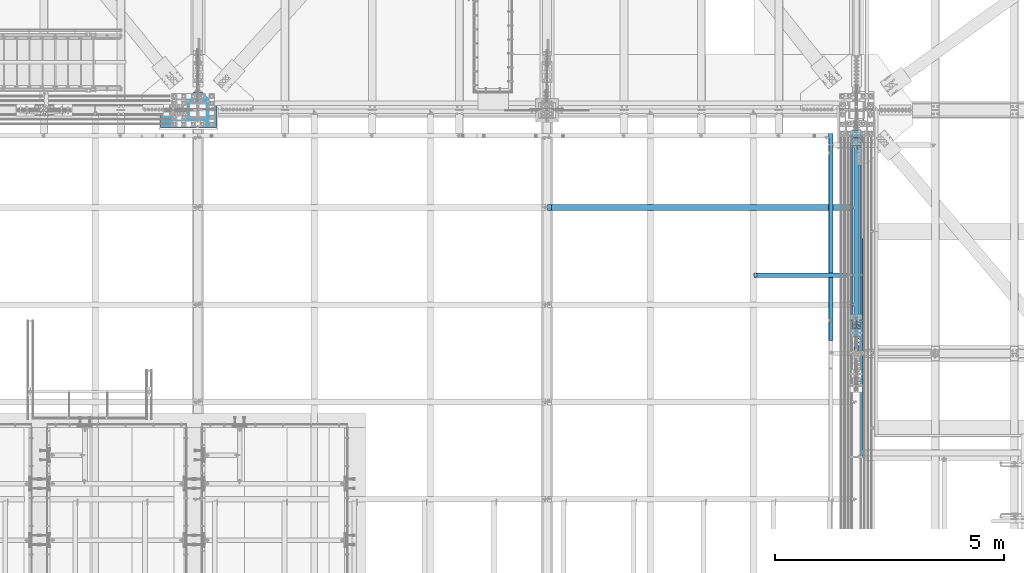
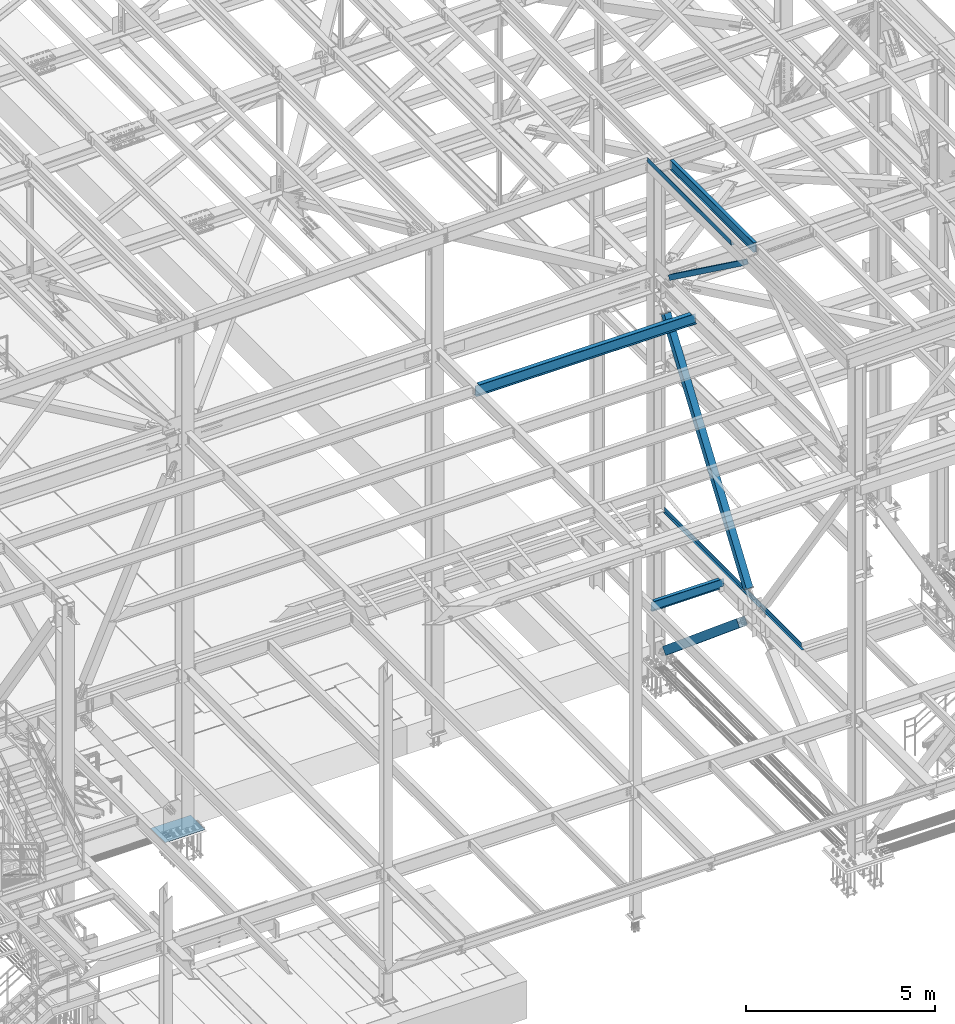
# One storey, part 1797 of 3843: 6 beams, 3 members, 9 elements without a shape of their own.
"""IFC2X3 building model written with IfcOpenShell, lengths in millimetres."""

from ifc_helpers import new_model, si_unit, frame, origin_with_axes, place, context, subcontext, project, spatial, faceted_brep, material, type_object, element, aggregate, save


model = new_model("IFC2X3")

# Units and contexts
model_context = context("Model", 3, precision=1e-05, world=origin_with_axes())
body_context = subcontext(model_context, "Body", "Model", "MODEL_VIEW")
ifc_project = project(units=[si_unit("LENGTHUNIT", "METRE", prefix="MILLI"), si_unit("AREAUNIT", "SQUARE_METRE"), si_unit("VOLUMEUNIT", "CUBIC_METRE"), si_unit("MASSUNIT", "GRAM", prefix="KILO"), si_unit("TIMEUNIT", "SECOND"), si_unit("PLANEANGLEUNIT", "RADIAN"), si_unit("SOLIDANGLEUNIT", "STERADIAN"), si_unit("THERMODYNAMICTEMPERATUREUNIT", "DEGREE_CELSIUS"), si_unit("LUMINOUSINTENSITYUNIT", "LUMEN")], contexts=[model_context])

# Site, building, storey
site_placement = place(None, origin_with_axes())
site = spatial("IfcSite", under=ifc_project, at=site_placement, CompositionType="ELEMENT")
building_placement = place(site_placement, origin_with_axes())
building = spatial("IfcBuilding", under=site, at=building_placement, Name="Undefined", CompositionType="ELEMENT")
storey_placement = place(building_placement, origin_with_axes())
storey = spatial("IfcBuildingStorey", under=building, at=storey_placement, Name="Undefined", CompositionType="ELEMENT", Elevation=0.0)

# Assembly, beam
assembly_1_placement = place(storey_placement, origin_with_axes())
assembly_1 = element("IfcElementAssembly", 1, at=assembly_1_placement, inside=storey, Name="CHANNEL", AssemblyPlace="NOTDEFINED", PredefinedType="RIGID_FRAME")
ifc_material_1 = material(Name="STEEL/A36")
beam_type_1 = type_object("IfcBeamType", PredefinedType="NOTDEFINED")
beam_1_placement = place(assembly_1_placement, frame((76504.7101110325, 22847.3, 46577.5353317129), z_axis=(0.0, -1.0, 0.0), x_axis=(-0.999776270257024, 0.0, -0.0211520550054595)))
beam_1 = element("IfcBeam", 2, at=beam_1_placement, type_object=beam_type_1, material=ifc_material_1, Name="BENT_PLATE", context=body_context, shape_type="Brep", body=[
    faceted_brep([(101.600000003906, -3.17499887833401, -2165.35000000001), (95.2500000038708, -3.17500000104337, -2165.35000000001), (95.2500000038708, -3.17500000104337, -2260.6), (101.600000003906, -3.17499887833401, -2260.6), (101.600000002873, -161.925000066476, -2165.34999999999), (95.2500000028231, -161.924999999166, -2165.34999999999), (4.36557456851006e-11, 3.17499999999563, -2260.6), (4.36557456851006e-11, 3.17499999999563, 2260.6), (101.600000003949, 3.17499999888241, 2260.6), (101.600000003949, 3.17499999888241, -2260.6), (-2.91038304567337e-11, -3.17499999999563, -2260.6), (-2.91038304567337e-11, -3.17499999999563, -2165.35000000001), (-2.91038304567337e-11, -3.17499999999563, 2260.6), (95.2500000038708, -3.17500000104337, 2260.6), (95.2500000028231, -161.924999999166, 2260.6), (101.600000002858, -161.924999999217, 2260.6)], [[[0, 1, 2, 3]], [[4, 5, 1, 0]], [[6, 7, 8, 9]], [[10, 11, 12, 7, 6]], [[8, 7, 12, 13, 14, 15]], [[3, 9, 8, 15, 4, 0]], [[10, 6, 9, 3, 2]], [[12, 11, 10, 2, 1, 13]], [[14, 13, 1, 5]], [[15, 14, 5, 4]]]),
])
aggregate(assembly_1, [beam_1])

assembly_2_placement = place(storey_placement, origin_with_axes())
assembly_2 = element("IfcElementAssembly", 3, at=assembly_2_placement, inside=storey, Name="BEAM", AssemblyPlace="NOTDEFINED", PredefinedType="RIGID_FRAME")
ifc_material_2 = material(Name="STEEL/A992")
beam_type_2 = type_object("IfcBeamType", Name="W12X19", PredefinedType="NOTDEFINED")
beam_2_placement = place(assembly_2_placement, frame((77012.7999999225, 20307.3, 46431.121693347), z_axis=(0.0, 0.0, 1.0), x_axis=(0.0, 1.0, 0.0)))
beam_2 = element("IfcBeam", 4, at=beam_2_placement, type_object=beam_type_2, material=ifc_material_2, Name="BEAM", ObjectType="W12X19", context=body_context, shape_type="Brep", body=[
    faceted_brep([(4479.92499999885, -3.17500000000291, -144.462500000001), (4479.92499999885, -50.8000000000029, -144.462500000001), (4479.92499999885, -50.8000000000029, -153.987500000003), (4479.92499999885, 50.8000000000029, -153.987500000003), (4479.92499999885, 50.8000000000029, -144.462500000001), (4479.92499999885, 3.17500000000291, -144.462500000001), (4479.92499999885, 3.17500000000291, -141.287499809056), (4479.92499999885, -3.17500000000291, -141.287499809056), (4480.89172992144, 3.17500000000291, -136.427420291009), (4480.89172992144, -3.17500000000291, -136.427420291009), (4483.64474382192, 3.17500000000291, -132.307243822856), (4483.64474382192, -3.17500000000291, -132.307243822856), (4487.76492029007, 3.17500000000291, -129.554229922382), (4487.76492029007, -3.17500000000291, -129.554229922382), (4492.62499980812, 3.17500000000291, -128.58749999979), (4492.62499980812, -3.17500000000291, -128.58749999979), (4530.72499999885, -3.17500000000291, -128.58749999979), (4530.72499999885, 3.17500000000291, -128.58749999979), (66.6750000000175, 3.17500000000291, 144.462500000001), (66.6750000000175, 50.8000000000029, 144.462500000001), (4479.92499999885, 50.8000000000029, 144.462500000001), (4479.92499999885, 3.17500000000291, 144.462500000001), (66.6750000000175, -3.17500000000291, -141.287499808226), (66.6750000000175, 3.17500000000291, -141.287499808226), (66.6750000000175, 3.17500000000291, -144.462500000001), (66.6750000000175, 50.8000000000029, -144.462500000001), (66.6750000000175, 50.8000000000029, -153.987500000003), (66.6750000000175, -50.8000000000029, -153.987500000003), (66.6750000000175, -50.8000000000029, -144.462500000001), (66.6750000000175, -3.17500000000291, -144.462500000001), (65.7082700774336, -3.17500000000291, -136.42742029018), (65.7082700774336, 3.17500000000291, -136.42742029018), (62.9552561769524, -3.17500000000291, -132.307243822026), (62.9552561769524, 3.17500000000291, -132.307243822026), (58.8350797087915, -3.17500000000291, -129.554229921552), (58.8350797087915, 3.17500000000291, -129.554229921552), (53.9750001907523, -3.17500000000291, -128.587499998961), (53.9750001907523, 3.17500000000291, -128.587499998961), (15.8750000000146, -3.17500000000291, -128.587499998961), (15.8750000000146, 3.17500000000291, -128.587499998961), (15.8750000000146, -3.17500000000291, 128.587500001042), (15.8750000000146, 3.17500000000291, 128.587500001042), (15.8750000000146, 3.17500000000291, 115.887500001612), (15.8750000000146, 3.17500000000291, -114.712499998386), (53.9750001907523, -3.17500000000291, 128.587500001042), (53.9750001907523, 3.17500000000291, 128.587500001042), (58.8350797087915, -3.17500000000291, 129.554229923633), (58.8350797087915, 3.17500000000291, 129.554229923633), (62.9552561769524, -3.17500000000291, 132.307243824107), (62.9552561769524, 3.17500000000291, 132.307243824107), (65.7082700774336, -3.17500000000291, 136.427420292261), (65.7082700774336, 3.17500000000291, 136.427420292261), (66.6750000000175, -3.17500000000291, 141.287499810307), (66.6750000000175, 3.17500000000291, 141.287499810307), (66.6750000000175, -50.8000000000029, 153.987500000003), (66.6750000000175, 50.8000000000029, 153.987500000003), (66.6750000000175, -3.17500000000291, 144.462500000001), (66.6750000000175, -50.8000000000029, 144.462500000001), (4479.92499999885, -3.17500000000291, 144.462500000001), (4479.92499999885, -50.8000000000029, 144.462500000001), (4479.92499999885, -50.8000000000029, 153.987500000003), (4479.92499999885, 50.8000000000029, 153.987500000003), (4479.92499999885, -3.17500000000291, 141.287499809478), (4479.92499999885, 3.17500000000291, 141.287499809478), (4480.89172992144, -3.17500000000291, 136.427420291431), (4480.89172992144, 3.17500000000291, 136.427420291431), (4483.64474382192, -3.17500000000291, 132.307243823278), (4483.64474382192, 3.17500000000291, 132.307243823278), (4487.76492029007, -3.17500000000291, 129.554229922804), (4487.76492029007, 3.17500000000291, 129.554229922804), (4492.62499980812, -3.17500000000291, 128.587500000212), (4492.62499980812, 3.17500000000291, 128.587500000212), (4530.72499999885, -3.17500000000291, 128.587500000212), (4530.72499999885, 3.17500000000291, 128.587500000212), (4530.72499999885, 3.17500000000291, -114.712499995876), (4530.72499999885, 3.17500000000291, 115.887500004123)], [[[0, 1, 2, 3, 4, 5, 6, 7]], [[7, 6, 8, 9]], [[9, 8, 10, 11]], [[11, 10, 12, 13]], [[13, 12, 14, 15]], [[16, 15, 14, 17]], [[18, 19, 20, 21]], [[22, 23, 24, 25, 26, 27, 28, 29]], [[30, 31, 23, 22]], [[32, 33, 31, 30]], [[34, 35, 33, 32]], [[36, 37, 35, 34]], [[38, 39, 37, 36]], [[40, 41, 42, 43, 39, 38]], [[44, 45, 41, 40]], [[46, 47, 45, 44]], [[48, 49, 47, 46]], [[50, 51, 49, 48]], [[52, 53, 51, 50]], [[54, 55, 19, 18, 53, 52, 56, 57]], [[57, 56, 58, 59]], [[54, 57, 59, 60]], [[55, 54, 60, 61]], [[19, 55, 61, 20]], [[60, 59, 58, 62, 63, 21, 20, 61]], [[64, 65, 63, 62]], [[66, 67, 65, 64]], [[68, 69, 67, 66]], [[70, 71, 69, 68]], [[72, 73, 71, 70]], [[74, 75, 73, 72, 16, 17]], [[12, 10, 8, 6, 5, 24, 23, 31, 33, 35, 37, 39, 43, 42, 41, 45, 47, 49, 51, 53, 18, 21, 63, 65, 67, 69, 71, 73, 75, 74, 17, 14]], [[25, 24, 5, 4]], [[26, 25, 4, 3]], [[27, 26, 3, 2]], [[28, 27, 2, 1]], [[29, 28, 1, 0]], [[72, 70, 68, 66, 64, 62, 58, 56, 52, 50, 48, 46, 44, 40, 38, 36, 34, 32, 30, 22, 29, 0, 7, 9, 11, 13, 15, 16]]]),
])
aggregate(assembly_2, [beam_2])

assembly_3_placement = place(storey_placement, origin_with_axes())
assembly_3 = element("IfcElementAssembly", 5, at=assembly_3_placement, inside=storey, Name="BEAM", AssemblyPlace="NOTDEFINED", PredefinedType="RIGID_FRAME")
beam_3_placement = place(assembly_3_placement, frame((74760.534374, 22009.1, 34656.7125), z_axis=(0.0, 0.0, 1.0), x_axis=(1.0, 0.0, 0.0)))
beam_3 = element("IfcBeam", 6, at=beam_3_placement, type_object=beam_type_2, material=ifc_material_2, Name="BEAM", ObjectType="W12X19", context=body_context, shape_type="Brep", body=[
    faceted_brep([(2093.51562600001, -3.17499999999927, -144.462500000001), (2093.51562600001, -50.7999999999993, -144.462500000001), (2093.51562600001, -50.7999999999993, -153.987500000003), (2093.51562600001, 50.7999999999993, -153.987500000003), (2093.51562600001, 50.7999999999993, -144.462500000001), (2093.51562600001, 3.17499999999927, -144.462500000001), (2093.51562600001, 3.17499999999927, -141.287499809259), (2093.51562600001, -3.17499999999927, -141.287499809259), (2094.48235592259, 3.17499999999927, -136.427420291213), (2094.48235592259, -3.17499999999927, -136.427420291213), (2097.23536982307, 3.17499999999927, -132.307243823059), (2097.23536982307, -3.17499999999927, -132.307243823059), (2101.35554629123, 3.17499999999927, -129.554229922585), (2101.35554629123, -3.17499999999927, -129.554229922585), (2106.21562580927, 3.17499999999927, -128.587499999994), (2106.21562580927, -3.17499999999927, -128.587499999994), (2233.215626, -3.17499999999927, -128.587499999994), (2233.215626, 3.17499999999927, -128.587499999994), (85.7250000000004, 3.17500000000291, 144.462500000001), (85.7250000000004, 50.8000000000029, 144.462500000001), (2093.51562600001, 50.7999999999993, 144.462500000001), (2093.51562600001, 3.17499999999927, 144.462500000001), (15.8750000000146, 3.17500000000291, 115.887500001612), (15.8750000000146, 3.17500000000291, -114.712499998386), (15.8749999999927, 3.17500000000291, -144.462500000001), (15.8749999999927, 50.8000000000029, -144.462500000001), (15.8749999999927, 50.8000000000029, -153.987500000003), (15.8749999999927, -50.8000000000029, -153.987500000003), (15.8749999999927, -50.8000000000029, -144.462500000001), (15.8749999999927, -3.17500000000291, -144.462500000001), (15.8750000000146, -3.17500000000291, 128.587500001042), (15.8750000000146, 3.17500000000291, 128.587500001042), (73.0250001907352, -3.17500000000291, 128.587500000001), (73.0250001907352, 3.17500000000291, 128.587500000001), (77.8850797087816, -3.17500000000291, 129.554229922593), (77.8850797087816, 3.17500000000291, 129.554229922593), (82.0052561769353, -3.17500000000291, 132.307243823067), (82.0052561769353, 3.17500000000291, 132.307243823067), (84.7582700774128, -3.17500000000291, 136.42742029122), (84.7582700774128, 3.17500000000291, 136.42742029122), (85.7250000000004, -3.17500000000291, 141.287499809267), (85.7250000000004, 3.17500000000291, 141.287499809267), (85.7250000000004, -50.8000000000029, 153.987500000003), (85.7250000000004, 50.8000000000029, 153.987500000003), (85.7250000000004, -3.17500000000291, 144.462500000001), (85.7250000000004, -50.8000000000029, 144.462500000001), (2093.51562600001, -3.17499999999927, 144.462500000001), (2093.51562600001, -50.7999999999993, 144.462500000001), (2093.51562600001, -50.7999999999993, 153.987500000003), (2093.51562600001, 50.7999999999993, 153.987500000003), (2093.51562600001, -3.17499999999927, 134.937499809275), (2093.51562600001, 3.17499999999927, 134.937499809275), (2094.48235592259, -3.17499999999927, 130.077420291229), (2094.48235592259, 3.17499999999927, 130.077420291229), (2097.23536982307, -3.17499999999927, 125.957243823075), (2097.23536982307, 3.17499999999927, 125.957243823075), (2101.35554629123, -3.17499999999927, 123.204229922601), (2101.35554629123, 3.17499999999927, 123.204229922601), (2106.21562580927, -3.17499999999927, 122.23750000001), (2106.21562580927, 3.17499999999927, 122.23750000001), (2233.215626, -3.17499999999927, 122.23750000001), (2233.215626, 3.17499999999927, 122.23750000001)], [[[0, 1, 2, 3, 4, 5, 6, 7]], [[7, 6, 8, 9]], [[9, 8, 10, 11]], [[11, 10, 12, 13]], [[13, 12, 14, 15]], [[16, 15, 14, 17]], [[18, 19, 20, 21]], [[22, 23, 24, 25, 26, 27, 28, 29, 30, 31]], [[32, 33, 31, 30]], [[34, 35, 33, 32]], [[36, 37, 35, 34]], [[38, 39, 37, 36]], [[40, 41, 39, 38]], [[42, 43, 19, 18, 41, 40, 44, 45]], [[45, 44, 46, 47]], [[42, 45, 47, 48]], [[43, 42, 48, 49]], [[19, 43, 49, 20]], [[48, 47, 46, 50, 51, 21, 20, 49]], [[52, 53, 51, 50]], [[54, 55, 53, 52]], [[56, 57, 55, 54]], [[58, 59, 57, 56]], [[60, 61, 59, 58]], [[61, 60, 16, 17]], [[12, 10, 8, 6, 5, 24, 23, 22, 31, 33, 35, 37, 39, 41, 18, 21, 51, 53, 55, 57, 59, 61, 17, 14]], [[25, 24, 5, 4]], [[26, 25, 4, 3]], [[27, 26, 3, 2]], [[28, 27, 2, 1]], [[29, 28, 1, 0]], [[60, 58, 56, 54, 52, 50, 46, 44, 40, 38, 36, 34, 32, 30, 29, 0, 7, 9, 11, 13, 15, 16]]]),
])
aggregate(assembly_3, [beam_3])

# Assembly, member
assembly_4_placement = place(storey_placement, origin_with_axes())
assembly_4 = element("IfcElementAssembly", 7, at=assembly_4_placement, inside=storey, Name="None", AssemblyPlace="NOTDEFINED", PredefinedType="RIGID_FRAME")
member_type_1 = type_object("IfcMemberType", Name="HSS8X8X3/16", PredefinedType="NOTDEFINED")
member_1_placement = place(assembly_4_placement, frame((77012.8, 20748.3232109174, 35210.3851700918), z_axis=(1.0, 0.0, 0.0), x_axis=(0.0, 0.571625300877386, 0.820514786824002)))
member_1 = element("IfcMember", 8, at=member_1_placement, type_object=member_type_1, material=ifc_material_2, Name="None", ObjectType="HSS8X8X3/16", context=body_context, shape_type="Brep", body=[
    faceted_brep([(2.03726813197136e-10, 96.8375000003298, -96.8374999999942), (-2.18278728425503e-10, -96.837500000317, -96.8374999999942), (7600.9499998327, -96.8375000032534, -96.8374999999942), (7600.94999983294, 96.8374999971061, -96.8374999999942), (-2.18278728425503e-10, -96.837500000317, 96.8374999999942), (7600.9499998327, -96.8375000032534, 96.8374999999942), (2.03726813197136e-10, 96.8375000003298, 96.8374999999942), (7600.94999983294, 96.8374999971061, 96.8374999999942), (2.18278728425503e-10, 101.600000000345, -101.600000000006), (2.18278728425503e-10, 101.600000000345, 101.600000000006), (7600.94999983296, 101.599999997118, 101.600000000006), (7600.94999983296, 101.599999997118, -101.600000000006), (-2.25554686039686e-10, -101.600000000329, 101.600000000006), (7600.94999983268, -101.600000003265, 101.600000000006), (-2.25554686039686e-10, -101.600000000329, -101.600000000006), (7600.94999983268, -101.600000003265, -101.600000000006)], [[[0, 1, 2, 3]], [[1, 4, 5, 2]], [[4, 6, 7, 5]], [[6, 0, 3, 7]], [[8, 9, 10, 11]], [[9, 12, 13, 10]], [[12, 14, 15, 13]], [[14, 8, 11, 15]], [[13, 15, 11, 10], [5, 7, 3, 2]], [[14, 12, 9, 8], [6, 4, 1, 0]]]),
])
aggregate(assembly_4, [member_1])

assembly_5_placement = place(storey_placement, origin_with_axes())
assembly_5 = element("IfcElementAssembly", 9, at=assembly_5_placement, inside=storey, Name="None", AssemblyPlace="NOTDEFINED", PredefinedType="RIGID_FRAME")
member_type_2 = type_object("IfcMemberType", Name="HSS10X10X1/4", PredefinedType="NOTDEFINED")
member_2_placement = place(assembly_5_placement, frame((77012.8, 24975.3904896878, 30672.8371723365), z_axis=(-1.0, 0.0, 0.0), x_axis=(0.0, -0.767054292974077, 0.641582193978323)))
member_2 = element("IfcMember", 10, at=member_2_placement, type_object=member_type_2, material=ifc_material_2, Name="None", ObjectType="HSS10X10X1/4", context=body_context, shape_type="Brep", body=[
    faceted_brep([(2.00088834390044e-10, 120.650000000089, -120.649999999994), (-2.03726813197136e-10, -120.650000000081, -120.649999999994), (5086.34999999408, -120.650000002657, -120.649999999994), (5086.34999999422, 120.649999997098, -120.649999999994), (-2.03726813197136e-10, -120.650000000081, 120.649999999994), (5086.34999999408, -120.650000002657, 120.649999999994), (2.00088834390044e-10, 120.650000000089, 120.649999999994), (5086.34999999422, 120.649999997098, 120.649999999994), (2.16459739021957e-10, 127.000000000087, -127.0), (2.16459739021957e-10, 127.000000000087, 127.0), (5086.34999999421, 126.99999999709, 127.0), (5086.34999999421, 126.99999999709, -127.0), (-2.14640749618411e-10, -127.00000000008, 127.0), (5086.34999999408, -127.000000002648, 127.0), (-2.14640749618411e-10, -127.00000000008, -127.0), (5086.34999999408, -127.000000002648, -127.0)], [[[0, 1, 2, 3]], [[1, 4, 5, 2]], [[4, 6, 7, 5]], [[6, 0, 3, 7]], [[8, 9, 10, 11]], [[9, 12, 13, 10]], [[12, 14, 15, 13]], [[14, 8, 11, 15]], [[13, 15, 11, 10], [5, 7, 3, 2]], [[14, 12, 9, 8], [6, 4, 1, 0]]]),
])
aggregate(assembly_5, [member_2])

# Assembly, beam
assembly_6_placement = place(storey_placement, origin_with_axes())
assembly_6 = element("IfcElementAssembly", 11, at=assembly_6_placement, inside=storey, Name="BEAM", AssemblyPlace="NOTDEFINED", PredefinedType="RIGID_FRAME")
beam_type_3 = type_object("IfcBeamType", PredefinedType="NOTDEFINED")
beam_4_placement = place(assembly_6_placement, frame((77103.288, 21743.988, 34813.875), z_axis=(0.0, -1.0, 0.0), x_axis=(1.0, 0.0, 0.0)))
beam_4 = element("IfcBeam", 12, at=beam_4_placement, type_object=beam_type_3, material=ifc_material_1, Name="BENT_PLATE", context=body_context, shape_type="Brep", body=[
    faceted_brep([(55.5620000000199, -3.17500000000291, 1417.63799960957), (55.5619999999908, 3.17500000000291, 1417.63799960957), (0.0, 3.17500000000291, 1417.63799960956), (0.0, -3.17500000000291, 1417.63799960956), (55.5619999999908, -3.17500000000291, 1455.73799960958), (55.5619999999908, 3.17500000000291, 1455.73799960958), (0.0, -3.17500000000291, 1455.73799960959), (0.0, 3.17500000000291, 1455.73799960959), (0.0, 3.17500000000291, 3678.2375), (0.0, -3.17500000000291, 3678.2375), (61.9119999999966, -3.17500000000291, 3678.2375), (61.9119999999966, 3.17499999999563, 3678.2375), (55.5619999999908, 3.17500000000291, 3678.2375), (0.0, 3.17500000000291, -3641.72499999999), (0.0, -3.17500000000291, -3641.72499999999), (55.5619999999908, 3.17500000000291, -3641.72499999999), (55.5619999999617, -3.17500000000291, -3641.72499999999), (55.5619999999908, 3.17500000000291, -3678.2375), (55.5619999999908, -3.17500000000291, -3678.2375), (55.5619999999908, 136.524999999994, -3678.2375), (61.9119999999966, 136.524999999994, -3678.2375), (61.9119999999966, -3.17500000000291, -3678.2375), (55.5619999999908, 136.524999999994, -3641.72499999999), (55.5619999999908, 136.524999999994, 1417.63799960957), (55.5619999999908, 136.524999999994, 1455.73799960958), (55.5619999999908, 136.524999999994, 3544.88800305176), (61.9119999999966, 136.524999999994, 3544.88800305176), (61.9119999999966, 3.17499694823346, 3544.88800305176), (55.5619999999908, 3.17500000000291, 3544.88800305176), (0.0, 3.17500000000291, 3544.88800305176)], [[[0, 1, 2, 3]], [[4, 5, 1, 0]], [[6, 7, 5, 4]], [[8, 9, 10, 11, 12]], [[13, 14, 3, 2]], [[15, 13, 2, 1]], [[14, 13, 15, 16]], [[16, 15, 17, 18]], [[19, 20, 21, 18, 17]], [[20, 19, 22, 23, 24, 25, 26]], [[10, 21, 20, 26, 27, 11]], [[11, 27, 28, 12]], [[26, 25, 28, 27]], [[24, 23, 22, 19, 17, 15, 1, 5, 28, 25]], [[29, 8, 12, 28, 5, 7]], [[9, 8, 29, 7, 6]], [[3, 14, 16, 18, 21, 10, 9, 6, 4, 0]]]),
])
aggregate(assembly_6, [beam_4])

# Assembly, member
assembly_7_placement = place(storey_placement, origin_with_axes())
assembly_7 = element("IfcElementAssembly", 13, at=assembly_7_placement, inside=storey, AssemblyPlace="NOTDEFINED", PredefinedType="RIGID_FRAME")
ifc_material_3 = material()
member_type_3 = type_object("IfcMemberType", Name="HSS6X6X3/8", PredefinedType="NOTDEFINED")
member_3_placement = place(assembly_7_placement, frame((77012.7999999709, 20307.2999995831, 46065.9735922786), z_axis=(1.0, 0.0, 0.0), x_axis=(0.0, 0.808168251917587, -0.588951675939947)))
member_3 = element("IfcMember", 14, at=member_3_placement, type_object=member_type_3, material=ifc_material_3, ObjectType="HSS6X6X3/8", context=body_context, shape_type="Brep", body=[
    faceted_brep([(5562.20236304537, -76.200000004188, 4.76249999999709), (5562.20236304537, -66.6750000041793, 4.76249999999709), (5462.18986304444, -66.6750000040993, 4.76249999999709), (5462.18986304444, -76.2000000041153, 4.76249999999709), (5459.15231330004, -66.6750000040993, 5.36670621068333), (5459.15231330003, -76.2000000041153, 5.36670621068333), (5456.57720296875, -66.675000004092, 7.08733992432826), (5456.57720296874, -76.2000000041153, 7.08733992432826), (5454.8565692551, -66.6750000040993, 9.66245025559328), (5454.85656925509, -76.2000000041153, 9.66245025559328), (5454.2523630444, -66.675000004092, 12.6999999999971), (5454.2523630444, -76.2000000041153, 12.6999999999971), (5454.8565692551, -66.6750000040993, 15.7375497444009), (5454.85656925509, -76.2000000041153, 15.7375497444009), (5456.57720296875, -66.675000004092, 18.3126600756659), (5456.57720296874, -76.2000000041153, 18.3126600756659), (5459.15231330004, -66.6750000040993, 20.0332937893108), (5459.15231330003, -76.2000000041153, 20.0332937893108), (5462.18986304444, -66.6750000040993, 20.6374999999971), (5462.18986304444, -76.2000000041153, 20.6374999999971), (5562.20236304537, -76.200000004188, 20.6374999999971), (5562.20236304537, -66.6750000041793, 20.6374999999971), (5562.20236304537, 66.6749999960812, 4.76249999999709), (5562.20236304537, 76.1999999960972, 4.76249999999709), (5462.18986304455, 76.1999999961699, 4.76249999999709), (5462.18986304455, 66.6749999961539, 4.76249999999709), (5459.15231330014, 76.1999999961699, 5.36670621068333), (5459.15231330013, 66.6749999961539, 5.36670621068333), (5456.57720296886, 76.1999999961772, 7.08733992432826), (5456.57720296885, 66.6749999961539, 7.08733992432826), (5454.8565692552, 76.1999999961772, 9.66245025559328), (5454.8565692552, 66.6749999961612, 9.66245025559328), (5454.25236304451, 76.1999999961772, 12.6999999999971), (5454.25236304451, 66.6749999961612, 12.6999999999971), (5454.8565692552, 76.1999999961772, 15.7375497444009), (5454.8565692552, 66.6749999961612, 15.7375497444009), (5456.57720296886, 76.1999999961772, 18.3126600756659), (5456.57720296885, 66.6749999961539, 18.3126600756659), (5459.15231330014, 76.1999999961699, 20.0332937893108), (5459.15231330013, 66.6749999961539, 20.0332937893108), (5462.18986304455, 76.1999999961699, 20.6374999999971), (5462.18986304455, 66.6749999961539, 20.6374999999971), (5562.20236304537, 66.6749999960812, 20.6374999999971), (5562.20236304537, 76.1999999960972, 20.6374999999971), (726.229730600618, -66.6750000006505, 66.6750000000029), (726.229730600615, 66.6749999996027, 66.6750000000029), (5562.20236304537, 66.6749999960812, 66.6750000000029), (5562.20236304537, -66.6750000041793, 66.6750000000029), (5562.20236304537, -66.6750000041793, -66.6750000000029), (726.229730600618, -66.6750000006505, -66.6750000000029), (726.229730600618, -66.6750000006505, -7.9375), (826.242230603679, -66.6750000007305, -7.9375), (829.279780348093, -66.6750000007305, -7.33329378931376), (831.854890679377, -66.6750000007305, -5.61266007566883), (833.575524393029, -66.6750000007305, -3.0375497444038), (834.179730603719, -66.6750000007305, 0.0), (833.575524393029, -66.6750000007305, 3.0375497444038), (831.854890679377, -66.6750000007305, 5.61266007566883), (829.279780348093, -66.6750000007305, 7.33329378931376), (826.242230603679, -66.6750000007305, 7.9375), (726.229730600618, -66.6750000006505, 7.9375), (726.229730600615, 66.6749999996027, -66.6750000000029), (5562.20236304537, 66.6749999960812, -66.6750000000029), (726.229730600615, 66.6749999996027, 7.9375), (726.229730600615, 76.1999999996187, 7.9375), (826.242230603781, 76.1999999995387, 7.9375), (826.242230603777, 66.6749999995227, 7.9375), (829.279780348199, 76.1999999995387, 7.33329378931376), (829.279780348192, 66.6749999995227, 7.33329378931376), (831.854890679486, 76.1999999995387, 5.61266007566883), (831.854890679475, 66.6749999995227, 5.61266007566883), (833.575524393134, 76.1999999995314, 3.0375497444038), (833.575524393123, 66.6749999995227, 3.0375497444038), (834.179730603828, 76.1999999995387, 0.0), (834.179730603817, 66.6749999995154, 0.0), (833.575524393134, 76.1999999995314, -3.0375497444038), (833.575524393123, 66.6749999995227, -3.0375497444038), (831.854890679486, 76.1999999995387, -5.61266007566883), (831.854890679475, 66.6749999995227, -5.61266007566883), (829.279780348199, 76.1999999995387, -7.33329378931376), (829.279780348192, 66.6749999995227, -7.33329378931376), (826.242230603781, 76.1999999995387, -7.9375), (826.242230603777, 66.6749999995227, -7.9375), (726.229730600615, 76.1999999996187, -7.9375), (726.229730600615, 66.6749999996027, -7.9375), (726.229730600615, 76.1999999996187, -76.1999999999971), (726.229730600615, -76.2000000006665, -76.1999999999971), (726.229730600615, -76.2000000006665, -7.9375), (826.242230603671, -76.2000000007465, -7.9375), (829.279780348086, -76.2000000007465, -7.33329378931376), (831.854890679369, -76.2000000007538, -5.61266007566883), (833.575524393022, -76.2000000007538, -3.0375497444038), (834.179730603715, -76.2000000007538, 0.0), (833.575524393022, -76.2000000007538, 3.0375497444038), (831.854890679369, -76.2000000007538, 5.61266007566883), (829.279780348086, -76.2000000007465, 7.33329378931376), (826.242230603671, -76.2000000007465, 7.9375), (726.229730600615, -76.2000000006665, 7.9375), (726.229730600615, -76.2000000006665, 76.1999999999971), (726.229730600615, 76.1999999996187, 76.1999999999971), (5562.20236304537, -76.200000004188, 76.1999999999971), (5562.20236304537, 76.1999999960972, 76.1999999999971), (5562.20236304537, 76.1999999960972, -76.1999999999971), (5562.20236304537, -76.200000004188, -76.1999999999971)], [[[0, 1, 2, 3]], [[3, 2, 4, 5]], [[5, 4, 6, 7]], [[7, 6, 8, 9]], [[9, 8, 10, 11]], [[11, 10, 12, 13]], [[13, 12, 14, 15]], [[15, 14, 16, 17]], [[17, 16, 18, 19]], [[20, 19, 18, 21]], [[22, 23, 24, 25]], [[25, 24, 26, 27]], [[27, 26, 28, 29]], [[29, 28, 30, 31]], [[31, 30, 32, 33]], [[33, 32, 34, 35]], [[35, 34, 36, 37]], [[37, 36, 38, 39]], [[39, 38, 40, 41]], [[42, 41, 40, 43]], [[44, 45, 46, 47]], [[16, 14, 12, 10, 8, 6, 4, 2, 1, 48, 49, 50, 51, 52, 53, 54, 55, 56, 57, 58, 59, 60, 44, 47, 21, 18]], [[61, 49, 48, 62]], [[63, 64, 65, 66]], [[66, 65, 67, 68]], [[68, 67, 69, 70]], [[70, 69, 71, 72]], [[72, 71, 73, 74]], [[74, 73, 75, 76]], [[76, 75, 77, 78]], [[78, 77, 79, 80]], [[80, 79, 81, 82]], [[82, 81, 83, 84]], [[49, 61, 84, 83, 85, 86, 87, 50]], [[88, 51, 50, 87]], [[89, 52, 51, 88]], [[90, 53, 52, 89]], [[91, 54, 53, 90]], [[92, 55, 54, 91]], [[93, 56, 55, 92]], [[94, 57, 56, 93]], [[95, 58, 57, 94]], [[96, 59, 58, 95]], [[97, 60, 59, 96]], [[98, 99, 64, 63, 45, 44, 60, 97]], [[99, 98, 100, 101]], [[47, 46, 42, 43, 101, 100, 20, 21]], [[38, 36, 34, 32, 30, 28, 26, 24, 23, 102, 85, 83, 81, 79, 77, 75, 73, 71, 69, 67, 65, 64, 99, 101, 43, 40]], [[86, 85, 102, 103]], [[100, 98, 97, 96, 95, 94, 93, 92, 91, 90, 89, 88, 87, 86, 103, 0, 3, 5, 7, 9, 11, 13, 15, 17, 19, 20]], [[103, 102, 23, 22, 62, 48, 1, 0]], [[46, 45, 63, 66, 68, 70, 72, 74, 76, 78, 80, 82, 84, 61, 62, 22, 25, 27, 29, 31, 33, 35, 37, 39, 41, 42]]]),
])
aggregate(assembly_7, [member_3])

# Assembly, beam
assembly_8_placement = place(storey_placement, origin_with_axes())
assembly_8 = element("IfcElementAssembly", 15, at=assembly_8_placement, inside=storey, Name="BEAM", AssemblyPlace="NOTDEFINED", PredefinedType="RIGID_FRAME")
beam_type_4 = type_object("IfcBeamType", Name="W14X26", PredefinedType="NOTDEFINED")
beam_5_placement = place(assembly_8_placement, frame((70256.4, 23492.46, 42292.5875), z_axis=(0.0, 0.0, 1.0), x_axis=(1.0, 0.0, 0.0)))
beam_5 = element("IfcBeam", 16, at=beam_5_placement, type_object=beam_type_4, material=ifc_material_2, Name="BEAM", ObjectType="W14X26", context=body_context, shape_type="Brep", body=[
    faceted_brep([(6588.12499999999, -63.5, 176.212500000001), (6588.12499999999, -63.5, 165.099999999999), (6588.12499999999, -3.17499999999927, 165.099999999999), (6588.12499999999, -3.17499999999927, 136.524999809262), (6588.12499999999, 3.17499999999927, 136.524999809262), (6588.12499999999, 3.17499999999927, 165.099999999999), (6588.12499999999, 63.5, 165.099999999999), (6588.12499999999, 63.5, 176.212500000001), (6589.09172992257, -3.17499999999927, 131.664920291216), (6589.09172992257, 3.17499999999927, 131.664920291216), (6591.84474382305, -3.17499999999927, 127.544743823062), (6591.84474382305, 3.17499999999927, 127.544743823062), (6595.96492029121, -3.17499999999927, 124.791729922588), (6595.96492029121, 3.17499999999927, 124.791729922588), (6600.82499980925, -3.17499999999927, 123.824999999997), (6600.82499980925, 3.17499999999927, 123.824999999997), (6737.34999999999, -3.17499999999927, 123.824999999997), (6737.34999999999, 3.17499999999927, 123.824999999997), (103.18750152587, -63.5, 176.212500000001), (103.18750152587, 63.5, 176.212500000001), (103.18750152587, 63.5, 165.099999999999), (103.18750152587, 3.17499999999927, 165.099999999999), (103.18750152587, 3.17499999999927, 153.987499809264), (103.18750152587, -3.17499999999927, 153.987499809264), (103.18750152587, -3.17499999999927, 165.099999999999), (103.18750152587, -63.5, 165.099999999999), (102.220771603286, 3.17499999999927, 149.127420291217), (102.220771603286, -3.17499999999927, 149.127420291217), (99.4677577028051, 3.17499999999927, 145.007243823064), (99.4677577028051, -3.17499999999927, 145.007243823064), (95.3475812346442, 3.17499999999927, 142.25422992259), (95.3475812346442, -3.17499999999927, 142.25422992259), (90.487501716605, 3.17499999999927, 141.287499999999), (90.487501716605, -3.17499999999927, 141.287499999999), (18.2562499999913, 3.17499999999927, 141.287499999999), (18.2562499999913, -3.17499999999927, 141.287499999999), (18.2562499999913, 3.17499999999927, 125.412499999999), (18.2562499999913, 3.17499999999927, -105.1875), (18.2562499999913, 3.17499999999927, -165.099999999999), (18.2562499999913, 63.5, -165.099999999999), (18.2562499999913, 63.5, -176.212500000001), (18.2562499999913, -63.5, -176.212500000001), (18.2562499999913, -63.5, -165.099999999999), (18.2562499999913, -3.17499999999927, -165.099999999999), (6737.34999999999, 3.17499999999927, -165.099999999999), (6737.34999999999, 63.5, -165.099999999999), (6737.34999999999, 63.5, -176.212500000001), (6737.34999999999, -63.5, -176.212500000001), (6737.34999999999, -63.5, -165.099999999999), (6737.34999999999, -3.17499999999927, -165.099999999999), (6737.34999999999, 3.17499999999927, -105.1875)], [[[0, 1, 2, 3, 4, 5, 6, 7]], [[8, 9, 4, 3]], [[10, 11, 9, 8]], [[12, 13, 11, 10]], [[14, 15, 13, 12]], [[16, 17, 15, 14]], [[18, 19, 20, 21, 22, 23, 24, 25]], [[23, 22, 26, 27]], [[27, 26, 28, 29]], [[29, 28, 30, 31]], [[31, 30, 32, 33]], [[33, 32, 34, 35]], [[36, 37, 38, 39, 40, 41, 42, 43, 35, 34]], [[39, 38, 44, 45]], [[40, 39, 45, 46]], [[41, 40, 46, 47]], [[42, 41, 47, 48]], [[43, 42, 48, 49]], [[12, 10, 8, 3, 2, 24, 23, 27, 29, 31, 33, 35, 43, 49, 16, 14]], [[25, 24, 2, 1]], [[18, 25, 1, 0]], [[19, 18, 0, 7]], [[20, 19, 7, 6]], [[21, 20, 6, 5]], [[50, 44, 38, 37, 36, 34, 32, 30, 28, 26, 22, 21, 5, 4, 9, 11, 13, 15, 17]], [[49, 48, 47, 46, 45, 44, 50, 17, 16]]]),
])
aggregate(assembly_8, [beam_5])

assembly_9_placement = place(storey_placement, origin_with_axes())
assembly_9 = element("IfcElementAssembly", 17, at=assembly_9_placement, inside=storey, Name="TEMPLATE", AssemblyPlace="NOTDEFINED", PredefinedType="RIGID_FRAME")
ifc_material_4 = material(Name="STEEL/A572-50")
beam_type_5 = type_object("IfcBeamType", PredefinedType="NOTDEFINED")
beam_6_placement = place(assembly_9_placement, frame((62433.2, 25234.9000030518, 29608.4625), z_axis=(-1.0, 0.0, 0.0), x_axis=(0.0, 1.0, 0.0)))
beam_6 = element("IfcBeam", 18, at=beam_6_placement, type_object=beam_type_5, material=ifc_material_4, Name="TEMPLATE", context=body_context, shape_type="Brep", body=[
    faceted_brep([(0.0, 4.76250000000073, -609.599999999999), (0.0, 4.76250000000073, 609.599999999999), (762.00001220702, 4.76250000000073, 609.599999999999), (762.00001220702, 4.76250000000073, -609.599999999999), (0.0, -4.76250000000073, 609.599999999999), (762.00001220702, -4.76250000000073, 609.599999999999), (0.0, -4.76250000000073, -609.599999999999), (762.00001220702, -4.76250000000073, -609.599999999999)], [[[0, 1, 2, 3]], [[1, 4, 5, 2]], [[4, 6, 7, 5]], [[6, 0, 3, 7]], [[5, 7, 3, 2]], [[6, 4, 1, 0]]]),
])
aggregate(assembly_9, [beam_6])

save(model, "model.ifc")
